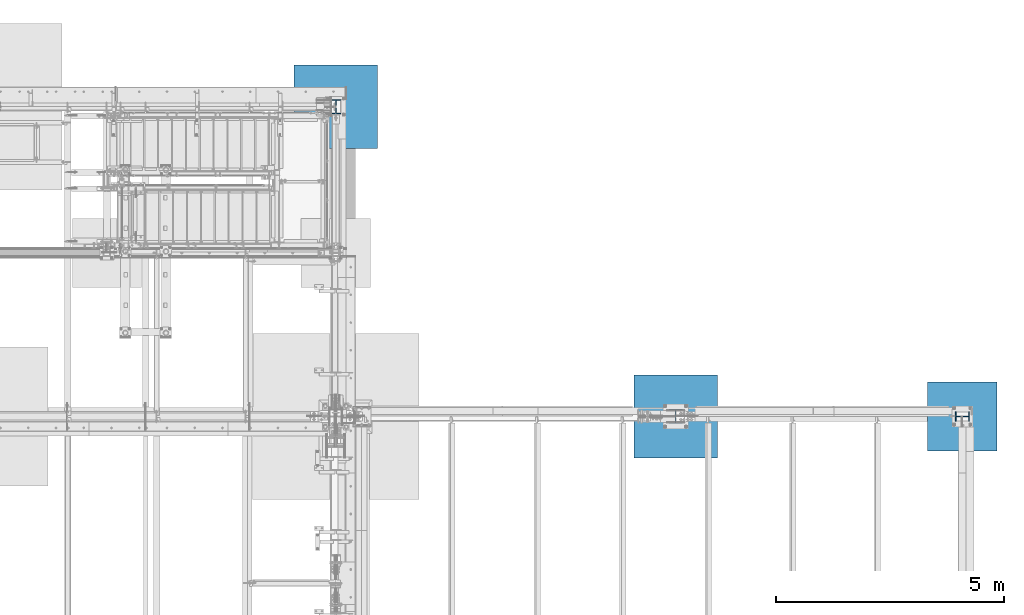
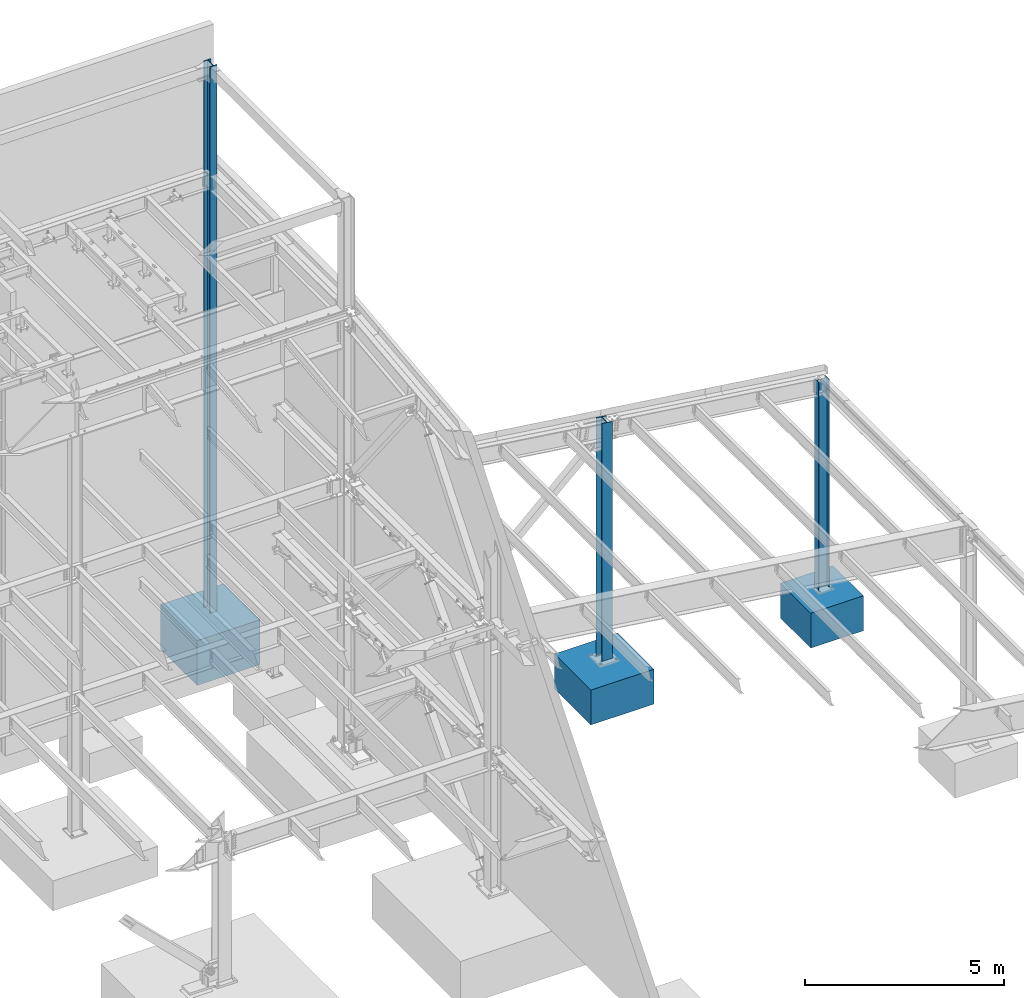
# One storey, part 379 of 1179: 6 columns, 6 elements without a shape of their own.
"""IFC2X3 building model written with IfcOpenShell, lengths in millimetres."""

import ifcopenshell
import ifcopenshell.guid

model = None  # the IFC model being written
_history = None  # IfcOwnerHistory: only IFC2X3 demands one
_inside = {}  # id of a spatial element -> (the spatial element, [elements in it])
_under = {}  # id of a project, library or spatial element -> (it, [spatial elements below it])
_declared = {}  # id of a project -> (the project, [libraries it declares])
_typed = {}  # id of a type object -> (the type object, [elements of that type])
_made_of = {}  # id of a material, layer set ... -> (it, [elements and type objects made of it])


def new_model(schema):
    """Start an empty IFC model of exactly this schema.

    Asked for "IFC4X3", IfcOpenShell would pick the latest addendum, in which some entities
    have other attributes; the version numbers below select the first issue.
    IFC2X3 requires an IfcOwnerHistory on every rooted entity: one is made here for all.
    """
    global model, _history
    if schema == "IFC4X3":
        model = ifcopenshell.file(schema_version=(4, 3, 0, 0))
    else:
        model = ifcopenshell.file(schema=schema)
    _inside.clear()
    _under.clear()
    _declared.clear()
    _typed.clear()
    _made_of.clear()
    _history = None
    if model.schema == "IFC2X3":
        org = make("IfcOrganization", Name="unknown")
        user = make(
            "IfcPersonAndOrganization",
            ThePerson=make("IfcPerson", FamilyName="unknown"),
            TheOrganization=org,
        )
        app = make(
            "IfcApplication",
            ApplicationDeveloper=org,
            Version="unknown",
            ApplicationFullName="unknown",
            ApplicationIdentifier="unknown",
        )
        _history = make(
            "IfcOwnerHistory",
            OwningUser=user,
            OwningApplication=app,
            ChangeAction="ADDED",
            CreationDate=0,
        )
    return model


def make(cls, **values):
    """One entity of the class cls with the attributes given. An attribute that is None is left unset."""
    return model.create_entity(
        cls, **{name: value for name, value in values.items() if value is not None}
    )


def rooted(cls, **values):
    """An entity with a GlobalId (a new one), such as an element, a storey or a relation."""
    return make(cls, GlobalId=ifcopenshell.guid.new(), OwnerHistory=_history, **values)


def si_unit(unit_type, name, prefix=None):
    """IfcSIUnit, for example si_unit("LENGTHUNIT", "METRE", prefix="MILLI")."""
    return make("IfcSIUnit", UnitType=unit_type, Prefix=prefix, Name=name)


def assignment(units):
    """IfcUnitAssignment: the units of a project."""
    return None if units is None else make("IfcUnitAssignment", Units=units)


def point(xyz):
    """IfcCartesianPoint."""
    return None if xyz is None else make("IfcCartesianPoint", Coordinates=xyz)


def direction(xyz):
    """IfcDirection."""
    return None if xyz is None else make("IfcDirection", DirectionRatios=xyz)


def frame(location, z_axis=None, x_axis=None):
    """IfcAxis2Placement3D, a coordinate frame: its origin and axes. An axis left out is left unset."""
    return make(
        "IfcAxis2Placement3D",
        Location=point(location),
        Axis=direction(z_axis),
        RefDirection=direction(x_axis),
    )


def origin_with_axes():
    """The frame at (0, 0, 0) with the z axis (0, 0, 1) and the x axis (1, 0, 0) written out."""
    return frame((0.0, 0.0, 0.0), z_axis=(0.0, 0.0, 1.0), x_axis=(1.0, 0.0, 0.0))


def place(relative_to, where):
    """IfcLocalPlacement: puts the frame where relative to a parent placement (None: the world)."""
    return make(
        "IfcLocalPlacement", PlacementRelTo=relative_to, RelativePlacement=where
    )


def context(
    kind, dimensions, precision=None, world=None, true_north=None, identifier=None
):
    """IfcGeometricRepresentationContext, for example the 3D "Model" context."""
    return make(
        "IfcGeometricRepresentationContext",
        ContextIdentifier=identifier,
        ContextType=kind,
        CoordinateSpaceDimension=dimensions,
        Precision=precision,
        WorldCoordinateSystem=world,
        TrueNorth=true_north,
    )


def subcontext(parent, identifier, kind, view, scale=None):
    """IfcGeometricRepresentationSubContext, for example "Body" below "Model"."""
    return make(
        "IfcGeometricRepresentationSubContext",
        ContextIdentifier=identifier,
        ContextType=kind,
        ParentContext=parent,
        TargetScale=scale,
        TargetView=view,
    )


def project(units=None, contexts=None):
    """IfcProject with its units and contexts."""
    return rooted(
        "IfcProject",
        Name="project",
        RepresentationContexts=contexts,
        UnitsInContext=assignment(units),
    )


def spatial(cls, under=None, at=None, **own):
    """A site, building, storey or space (cls), placed at a placement, below another one or the project."""
    s = rooted(cls, ObjectPlacement=at, **own)
    if under is not None:
        _under.setdefault(under.id(), (under, []))[1].append(s)
    return s


def faces_of(points, faces, orient=None, outer=None):
    """IfcFace entities. A face is a list of loops; a loop is a list of indices into points, from 0.

    orient and outer hold one flag for each loop. By default every Orientation is true, the
    first loop of a face is its IfcFaceOuterBound and the others are IfcFaceBound.
    """
    made = []
    for i, loops in enumerate(faces):
        bounds = []
        for j, loop in enumerate(loops):
            is_outer = j == 0 if outer is None else outer[i][j]
            bounds.append(
                make(
                    "IfcFaceOuterBound" if is_outer else "IfcFaceBound",
                    Bound=make("IfcPolyLoop", Polygon=[points[k] for k in loop]),
                    Orientation=True if orient is None else orient[i][j],
                )
            )
        made.append(make("IfcFace", Bounds=bounds))
    return made


def faceted_brep(points, faces, orient=None, outer=None, voids=None):
    """IfcFacetedBrep: a solid bounded by flat faces; with voids (closed shells), ...WithVoids."""
    shared = [point(p) for p in points]
    hull = make("IfcClosedShell", CfsFaces=faces_of(shared, faces, orient, outer))
    if voids is None:
        return make("IfcFacetedBrep", Outer=hull)
    return make(
        "IfcFacetedBrepWithVoids",
        Outer=hull,
        Voids=[
            make(cls, CfsFaces=faces_of(shared, fs, o, b)) for cls, fs, o, b in voids
        ],
    )


def shape(context_of_items, identifier, shape_type, items):
    """IfcShapeRepresentation: the items that make up one representation, for example the "Body"."""
    return make(
        "IfcShapeRepresentation",
        ContextOfItems=context_of_items,
        RepresentationIdentifier=identifier,
        RepresentationType=shape_type,
        Items=items,
    )


def material(Name=None, Category=None):
    """IfcMaterial."""
    return make("IfcMaterial", Name=Name, Category=Category)


def made_of(thing, what):
    """Note that an element or type object is made of a material, layer set ...; save() writes the relation."""
    if what is not None:
        _made_of.setdefault(what.id(), (what, []))[1].append(thing)
    return thing


def type_object(cls, material=None, **own):
    """A type object (cls), such as IfcWallType, which elements share."""
    return made_of(rooted(cls, **own), material)


def element(
    cls,
    number,
    at=None,
    inside=None,
    cuts=None,
    type_object=None,
    material=None,
    context=None,
    identifier="Body",
    shape_type=None,
    held_by="IfcProductDefinitionShape",
    body=None,
    shapes=None,
    **own,
):
    """One element of the class cls, such as IfcWall. Its Tag is "e" and its number.

    at: its placement. inside: the storey or other place that contains it. cuts: it is an
    opening in that element (IfcRelVoidsElement). A single representation is given by context,
    identifier, shape_type and body (its items); several are given by shapes. held_by: the class
    of the entity that holds the representations. save() writes the other relations.
    """
    e = rooted(cls, Tag="e%d" % number, ObjectPlacement=at, **own)
    if body is not None:
        shapes = [shape(context, identifier, shape_type, body)]
    if shapes is not None:
        e.Representation = make(held_by, Representations=shapes)
    if inside is not None:
        _inside.setdefault(inside.id(), (inside, []))[1].append(e)
    if cuts is not None:
        rooted(
            "IfcRelVoidsElement", RelatingBuildingElement=cuts, RelatedOpeningElement=e
        )
    if type_object is not None:
        _typed.setdefault(type_object.id(), (type_object, []))[1].append(e)
    return made_of(e, material)


def aggregate(whole, parts):
    """IfcRelAggregates: a whole, such as a stair, and the parts it consists of."""
    return rooted("IfcRelAggregates", RelatingObject=whole, RelatedObjects=parts)


def save(model, path):
    """Write the relations noted so far, then the file.

    IfcRelAggregates (storeys below a building ...), IfcRelContainedInSpatialStructure (elements
    in a storey), IfcRelDefinesByType, IfcRelAssociatesMaterial and IfcRelDeclares: one each for
    every whole, place, type object, material and project.
    """
    for whole, parts in _under.values():
        aggregate(whole, parts)
    for where, things in _inside.values():
        rooted(
            "IfcRelContainedInSpatialStructure",
            RelatedElements=things,
            RelatingStructure=where,
        )
    for kind, things in _typed.values():
        rooted("IfcRelDefinesByType", RelatedObjects=things, RelatingType=kind)
    for what, things in _made_of.values():
        rooted("IfcRelAssociatesMaterial", RelatedObjects=things, RelatingMaterial=what)
    for by, libraries in _declared.values():
        rooted("IfcRelDeclares", RelatingContext=by, RelatedDefinitions=libraries)
    model.write(path)


model = new_model("IFC2X3")

# Units and contexts
model_context = context("Model", 3, precision=1e-05, world=origin_with_axes())
body_context = subcontext(model_context, "Body", "Model", "MODEL_VIEW")
ifc_project = project(units=[si_unit("LENGTHUNIT", "METRE", prefix="MILLI"), si_unit("AREAUNIT", "SQUARE_METRE"), si_unit("VOLUMEUNIT", "CUBIC_METRE"), si_unit("MASSUNIT", "GRAM", prefix="KILO"), si_unit("TIMEUNIT", "SECOND"), si_unit("PLANEANGLEUNIT", "RADIAN"), si_unit("SOLIDANGLEUNIT", "STERADIAN"), si_unit("THERMODYNAMICTEMPERATUREUNIT", "DEGREE_CELSIUS"), si_unit("LUMINOUSINTENSITYUNIT", "LUMEN")], contexts=[model_context])

# Site, building, storey
site_placement = place(None, origin_with_axes())
site = spatial("IfcSite", under=ifc_project, at=site_placement, CompositionType="ELEMENT")
building_placement = place(site_placement, origin_with_axes())
building = spatial("IfcBuilding", under=site, at=building_placement, Name="Undefined", CompositionType="ELEMENT")
storey_placement = place(building_placement, origin_with_axes())
storey = spatial("IfcBuildingStorey", under=building, at=storey_placement, Name="Undefined", CompositionType="ELEMENT", Elevation=0.0)

# Assembly, column
assembly_1_placement = place(storey_placement, origin_with_axes())
assembly_1 = element("IfcElementAssembly", 1, at=assembly_1_placement, inside=storey, Name="FOOTING", AssemblyPlace="NOTDEFINED", PredefinedType="REINFORCEMENT_UNIT")
ifc_material_1 = material(Name="CONCRETE/3000")
column_type_1 = type_object("IfcColumnType", PredefinedType="NOTDEFINED")
column_1_placement = place(assembly_1_placement, frame((38074.6, 34391.6, -1422.4), z_axis=(-1.0, 0.0, 0.0), x_axis=(0.0, 0.0, 1.0)))
column_1 = element("IfcColumn", 2, at=column_1_placement, type_object=column_type_1, material=ifc_material_1, Name="FOOTING", context=body_context, shape_type="Brep", body=[
    faceted_brep([(0.0, 761.999999999822, -761.999999999945), (0.0, 761.999999999945, 761.99999999982), (1066.8, 762.0, 762.0), (1066.8, 762.0, -762.0), (0.0, -761.999999999821, 761.999999999942), (1066.8, -762.0, 762.0), (0.0, -761.999999999944, -761.999999999822), (1066.8, -762.0, -762.0)], [[[0, 1, 2, 3]], [[1, 4, 5, 2]], [[4, 6, 7, 5]], [[6, 0, 3, 7]], [[5, 7, 3, 2]], [[6, 4, 1, 0]]]),
])
aggregate(assembly_1, [column_1])

assembly_2_placement = place(storey_placement, origin_with_axes())
assembly_2 = element("IfcElementAssembly", 3, at=assembly_2_placement, inside=storey, Name="FOOTING", AssemblyPlace="NOTDEFINED", PredefinedType="REINFORCEMENT_UNIT")
column_type_2 = type_object("IfcColumnType", PredefinedType="NOTDEFINED")
column_2_placement = place(assembly_2_placement, frame((31775.4, 34391.6, -1422.4), z_axis=(-1.0, 0.0, 0.0), x_axis=(0.0, 0.0, 1.0)))
column_2 = element("IfcColumn", 4, at=column_2_placement, type_object=column_type_2, material=ifc_material_1, Name="FOOTING", context=body_context, shape_type="Brep", body=[
    faceted_brep([(0.0, 914.400000000001, -914.400000000001), (0.0, 914.400000000001, 914.400000000001), (1066.8, 914.400000000001, 914.400000000001), (1066.8, 914.400000000001, -914.400000000001), (0.0, -914.400000000001, 914.400000000001), (1066.8, -914.400000000001, 914.400000000001), (0.0, -914.400000000001, -914.400000000001), (1066.8, -914.400000000001, -914.400000000001)], [[[0, 1, 2, 3]], [[1, 4, 5, 2]], [[4, 6, 7, 5]], [[6, 0, 3, 7]], [[5, 7, 3, 2]], [[6, 4, 1, 0]]]),
])
aggregate(assembly_2, [column_2])

assembly_3_placement = place(storey_placement, origin_with_axes())
assembly_3 = element("IfcElementAssembly", 5, at=assembly_3_placement, inside=storey, Name="FOOTING", AssemblyPlace="NOTDEFINED", PredefinedType="REINFORCEMENT_UNIT")
column_3_placement = place(assembly_3_placement, frame((24307.8, 41198.8, -1727.2), z_axis=(-1.0, 0.0, 0.0), x_axis=(0.0, 0.0, 1.0)))
column_3 = element("IfcColumn", 6, at=column_3_placement, type_object=column_type_2, material=ifc_material_1, Name="FOOTING", context=body_context, shape_type="Brep", body=[
    faceted_brep([(0.0, 914.400000000001, -914.400000000001), (0.0, 914.400000000001, 914.400000000001), (1371.6, 914.400000000001, 914.400000000001), (1371.6, 914.400000000001, -914.400000000001), (0.0, -914.400000000001, 914.400000000001), (1371.6, -914.400000000001, 914.400000000001), (0.0, -914.400000000001, -914.400000000001), (1371.6, -914.400000000001, -914.400000000001)], [[[0, 1, 2, 3]], [[1, 4, 5, 2]], [[4, 6, 7, 5]], [[6, 0, 3, 7]], [[5, 7, 3, 2]], [[6, 4, 1, 0]]]),
])
aggregate(assembly_3, [column_3])

assembly_4_placement = place(storey_placement, origin_with_axes())
assembly_4 = element("IfcElementAssembly", 7, at=assembly_4_placement, inside=storey, Name="COLUMN", AssemblyPlace="NOTDEFINED", PredefinedType="RIGID_FRAME")
ifc_material_2 = material(Name="STEEL/A992")
column_type_3 = type_object("IfcColumnType", Name="W12X50", PredefinedType="NOTDEFINED")
column_4_placement = place(assembly_4_placement, frame((38074.6, 34391.6, -355.6), z_axis=(-1.0, 0.0, 0.0), x_axis=(0.0, 0.0, 1.0)))
column_4 = element("IfcColumn", 8, at=column_4_placement, type_object=column_type_3, material=ifc_material_2, Name="COLUMN", ObjectType="W12X50", context=body_context, shape_type="Brep", body=[
    faceted_brep([(88.8999999999996, 103.1875, -155.574999999997), (88.8999999999996, 103.1875, -139.699999999997), (6451.6, 103.1875, -139.699999999997), (6451.6, 103.1875, -155.574999999997), (88.8999999999996, 4.76249999999982, -139.699999999997), (6451.6, 4.76249999999982, -139.699999999997), (88.8999999999996, 4.76249999999982, 139.699999999997), (6451.6, 4.76249999999982, 139.699999999997), (88.8999999999996, 103.1875, 139.699999999997), (6451.6, 103.1875, 139.699999999997), (88.8999999999996, 103.1875, 155.574999999997), (6451.6, 103.1875, 155.574999999997), (88.8999999999996, -103.1875, 155.574999999997), (6451.6, -103.1875, 155.574999999997), (88.8999999999996, -103.1875, 139.699999999997), (6451.6, -103.1875, 139.699999999997), (88.8999999999996, -4.76249999999982, 139.699999999997), (6451.6, -4.76249999999982, 139.699999999997), (88.8999999999996, -4.76249999999982, -139.699999999997), (6451.6, -4.76249999999982, -139.699999999997), (88.8999999999996, -103.1875, -139.699999999997), (6451.6, -103.1875, -139.699999999997), (88.8999999999996, -103.1875, -155.574999999997), (6451.6, -103.1875, -155.574999999997)], [[[0, 1, 2, 3]], [[1, 4, 5, 2]], [[4, 6, 7, 5]], [[6, 8, 9, 7]], [[8, 10, 11, 9]], [[10, 12, 13, 11]], [[12, 14, 15, 13]], [[14, 16, 17, 15]], [[16, 18, 19, 17]], [[18, 20, 21, 19]], [[20, 22, 23, 21]], [[22, 0, 3, 23]], [[5, 7, 9, 11, 13, 15, 17, 19, 21, 23, 3, 2]], [[22, 20, 18, 16, 14, 12, 10, 8, 6, 4, 1, 0]]]),
])
aggregate(assembly_4, [column_4])

assembly_5_placement = place(storey_placement, origin_with_axes())
assembly_5 = element("IfcElementAssembly", 9, at=assembly_5_placement, inside=storey, Name="COLUMN", AssemblyPlace="NOTDEFINED", PredefinedType="RIGID_FRAME")
column_5_placement = place(assembly_5_placement, frame((24307.8, 41198.8, -355.6), z_axis=(0.0, 1.0, 0.0), x_axis=(0.0, 0.0, 1.0)))
column_5 = element("IfcColumn", 10, at=column_5_placement, type_object=column_type_3, material=ifc_material_2, Name="COLUMN", ObjectType="W12X50", context=body_context, shape_type="Brep", body=[
    faceted_brep([(88.8999999999996, 103.1875, -155.574999999997), (88.8999999999996, 103.1875, -139.699999999997), (16814.8, 103.1875, -139.699999999997), (16814.8, 103.1875, -155.574999999997), (88.8999999999996, 4.76249999999982, -139.699999999997), (16814.8, 4.76250000000073, -139.699999999997), (88.8999999999996, 4.76249999999982, 139.699999999997), (16814.8, 4.76250000000073, 139.699999999997), (88.8999999999996, 103.1875, 139.699999999997), (16814.8, 103.1875, 139.699999999997), (88.8999999999996, 103.1875, 155.574999999997), (16814.8, 103.1875, 155.574999999997), (88.8999999999996, -103.1875, 155.574999999997), (16814.8, -103.1875, 155.574999999997), (88.8999999999996, -103.1875, 139.699999999997), (16814.8, -103.1875, 139.699999999997), (88.8999999999996, -4.76249999999982, 139.699999999997), (16814.8, -4.76250000000073, 139.699999999997), (88.8999999999996, -4.76249999999982, -139.699999999997), (16814.8, -4.76250000000073, -139.699999999997), (88.8999999999996, -103.1875, -139.699999999997), (16814.8, -103.1875, -139.699999999997), (88.8999999999996, -103.1875, -155.574999999997), (16814.8, -103.1875, -155.574999999997)], [[[0, 1, 2, 3]], [[1, 4, 5, 2]], [[4, 6, 7, 5]], [[6, 8, 9, 7]], [[8, 10, 11, 9]], [[10, 12, 13, 11]], [[12, 14, 15, 13]], [[14, 16, 17, 15]], [[16, 18, 19, 17]], [[18, 20, 21, 19]], [[20, 22, 23, 21]], [[22, 0, 3, 23]], [[5, 7, 9, 11, 13, 15, 17, 19, 21, 23, 3, 2]], [[22, 20, 18, 16, 14, 12, 10, 8, 6, 4, 1, 0]]]),
])
aggregate(assembly_5, [column_5])

assembly_6_placement = place(storey_placement, origin_with_axes())
assembly_6 = element("IfcElementAssembly", 11, at=assembly_6_placement, inside=storey, Name="COLUMN", AssemblyPlace="NOTDEFINED", PredefinedType="RIGID_FRAME")
column_type_4 = type_object("IfcColumnType", Name="W12X72", PredefinedType="NOTDEFINED")
column_6_placement = place(assembly_6_placement, frame((31775.4, 34391.6, -355.6), z_axis=(0.0, 1.0, 0.0), x_axis=(0.0, 0.0, 1.0)))
column_6 = element("IfcColumn", 12, at=column_6_placement, type_object=column_type_4, material=ifc_material_2, Name="COLUMN", ObjectType="W12X72", context=body_context, shape_type="Brep", body=[
    faceted_brep([(146.606600357246, -152.400000000001, 155.574999999997), (146.606600357246, 152.400000000001, 155.574999999997), (136.524983529018, 152.400000000001, 138.112500000003), (136.524983529014, 5.55625019064973, 138.112499999996), (136.29578370764, 5.5562501866807, 137.715499999998), (136.29578370764, -5.55625000000146, 137.715499999998), (136.524983529018, -5.55625000000146, 138.112500000003), (136.524983529018, -152.400000000001, 138.112500000003), (7387.35452398489, 152.400000000001, -155.574999999997), (7428.51093193403, -152.400000000001, -155.574999999997), (146.606617700325, -152.400000000001, -155.574999999997), (146.606617700325, 152.400000000001, -155.574999999997), (7428.51093193403, -152.400000000001, -138.112500000003), (136.525382299677, -152.400000000001, -138.112500000003), (7408.68297497937, -5.55625000000146, -138.112500000003), (136.525382299677, -5.55625000000146, -138.112500000003), (174.625000000001, -5.55625000000146, 137.715499999998), (174.625000000001, 5.55625013626559, 137.715499999998), (194.202660582074, 5.55625013373719, 131.287141068809), (194.202660582074, -5.55625000000146, 131.287141068809), (198.585373738856, 5.55625013263489, 128.290736246861), (198.585373738856, -5.55625000000146, 128.290736246861), (200.683292158598, 5.55625013091776, 123.41371309993), (200.683292158598, -5.55625000000146, 123.41371309993), (199.844634973188, 5.5562501291206, 118.171264187738), (199.844634973188, -5.55625000000146, 118.171264187738), (196.329956026479, 5.55625012780001, 114.192112472469), (196.329956026479, -5.55625000000146, 114.192112472469), (191.231195059057, 5.55625012737073, 112.712500000001), (191.231195059057, -5.55625000000146, 112.712500000001), (127.000000000001, 5.55625000000146, 112.712500000001), (133.415804862977, -5.55625017319471, 112.712500000001), (127.000000000001, 5.55625000000146, -112.712500000001), (133.415804862978, -5.55625001754015, -112.712500000001), (191.231195059057, 5.55625005558613, -112.712500000001), (191.231195059057, -5.55625000000146, -112.712500000001), (196.32995602648, 5.55625005499678, -114.192112472469), (196.32995602648, -5.55625000000146, -114.192112472469), (199.844634973189, 5.55625005357069, -118.171264187738), (199.844634973189, -5.55625000000146, -118.171264187738), (200.683292158599, 5.55625005174807, -123.41371309993), (200.683292158599, -5.55625000000146, -123.41371309993), (198.585373738856, 5.55625005009642, -128.290736246861), (198.585373738856, -5.55625000000146, -128.290736246861), (194.202660582074, 5.55625004912872, -131.287141068809), (194.202660582074, -5.55625000000146, -131.287141068809), (174.625000000001, 5.55625004720423, -137.715499999998), (174.625000000001, -5.55625000000146, -137.715499999998), (136.296191149838, 5.55625000355576, -137.715499999998), (136.296191149838, -5.55625000000146, -137.715499999998), (7407.18248093956, 5.55625000000146, -138.112500000003), (7387.35452398489, 152.400000000001, -138.112500000003), (136.525382299677, 152.400000000001, -138.112500000003), (136.525382299677, 5.55625000000146, -138.112500000003), (7407.18248093956, 5.55625000000146, 138.112500000003), (7387.35452398489, 152.400000000001, 138.112500000003), (7387.35452398489, 152.400000000001, 155.574999999997), (7428.51093193403, -152.400000000001, 155.574999999997), (7428.51093193403, -152.400000000001, 138.112500000003), (7408.68297497937, -5.55625000000146, 138.112500000003)], [[[0, 1, 2, 3, 4, 5, 6, 7]], [[8, 9, 10, 11]], [[9, 12, 13, 10]], [[12, 14, 15, 13]], [[16, 17, 18, 19]], [[19, 18, 20, 21]], [[21, 20, 22, 23]], [[23, 22, 24, 25]], [[25, 24, 26, 27]], [[27, 26, 28, 29]], [[29, 28, 30, 31]], [[32, 33, 31, 30]], [[33, 32, 34, 35]], [[35, 34, 36, 37]], [[37, 36, 38, 39]], [[39, 38, 40, 41]], [[41, 40, 42, 43]], [[43, 42, 44, 45]], [[45, 44, 46, 47]], [[47, 46, 48, 49]], [[50, 51, 52, 53]], [[10, 13, 15, 49, 48, 53, 52, 11]], [[51, 8, 11, 52]], [[50, 54, 55, 56, 57, 58, 59, 14, 12, 9, 8, 51]], [[58, 57, 0, 7]], [[59, 58, 7, 6]], [[16, 19, 21, 23, 25, 27, 29, 31, 33, 35, 37, 39, 41, 43, 45, 47, 49, 15, 14, 59, 6, 5]], [[17, 16, 5, 4]], [[54, 50, 53, 48, 46, 44, 42, 40, 38, 36, 34, 32, 30, 28, 26, 24, 22, 20, 18, 17, 4, 3]], [[55, 54, 3, 2]], [[56, 55, 2, 1]], [[57, 56, 1, 0]]]),
])
aggregate(assembly_6, [column_6])

save(model, "model.ifc")
